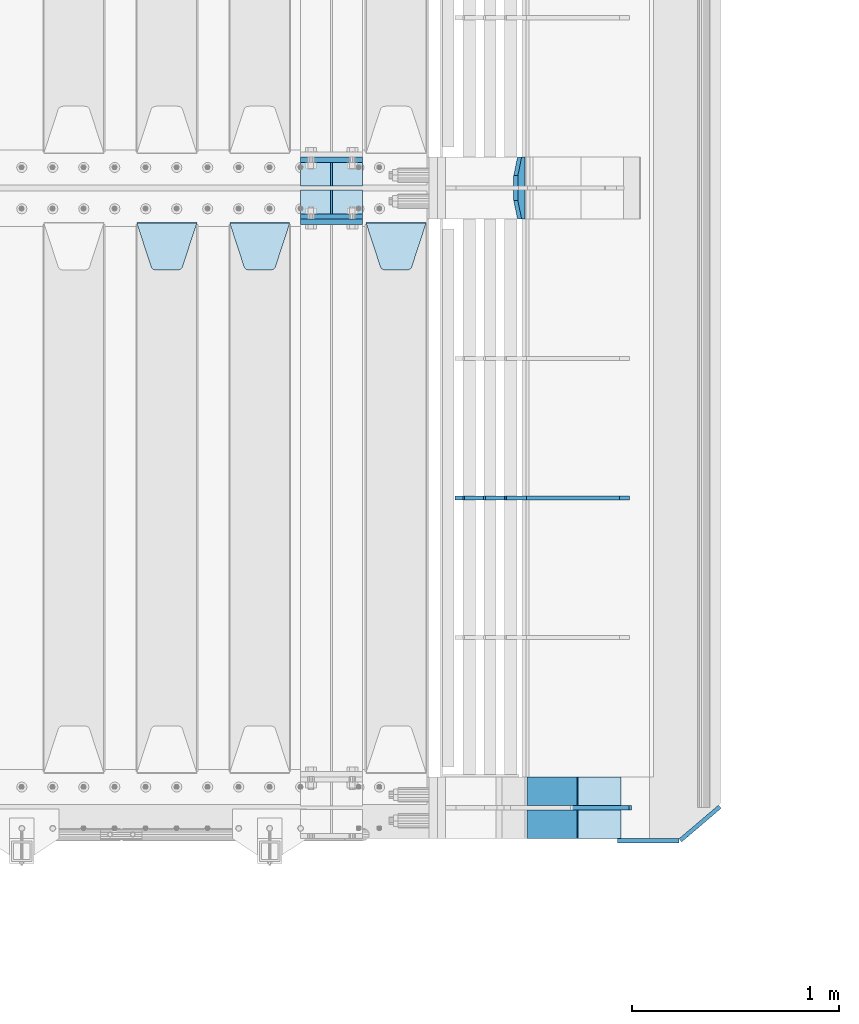
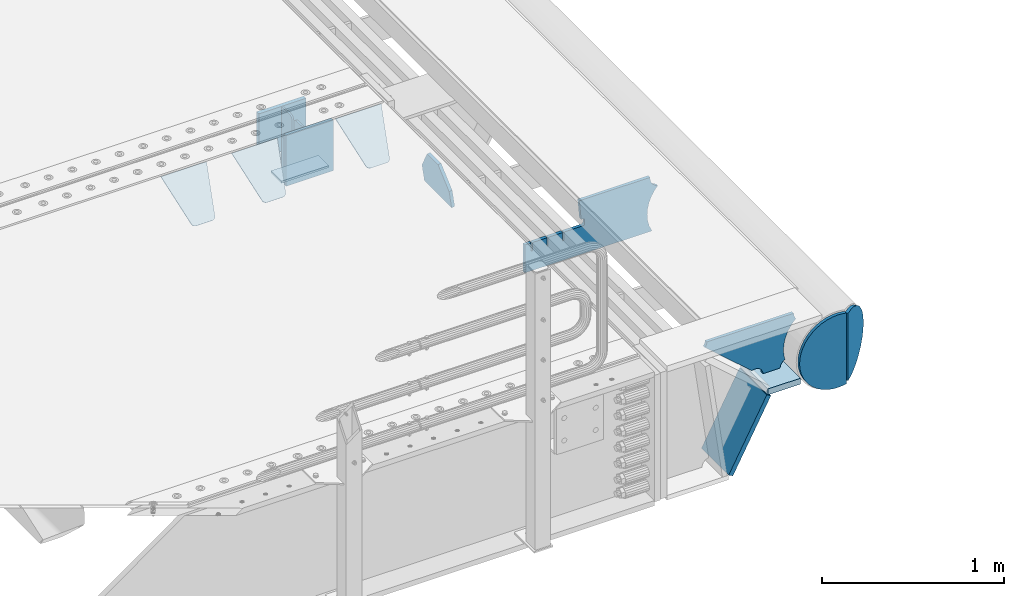
# One storey, part 243 of 270: 17 plates.
"""IFC2X3 building model written with IfcOpenShell, lengths in millimetres."""

from ifc_helpers import new_model, si_unit, frame, origin_with_axes, place, context, subcontext, project, spatial, faceted_brep, material, type_object, element, save


model = new_model("IFC2X3")

# Units and contexts
model_context = context("Model", 3, precision=1e-05, world=origin_with_axes())
body_context = subcontext(model_context, "Body", "Model", "MODEL_VIEW")
ifc_project = project(units=[si_unit("LENGTHUNIT", "METRE", prefix="MILLI"), si_unit("AREAUNIT", "SQUARE_METRE"), si_unit("VOLUMEUNIT", "CUBIC_METRE"), si_unit("MASSUNIT", "GRAM", prefix="KILO"), si_unit("TIMEUNIT", "SECOND"), si_unit("PLANEANGLEUNIT", "RADIAN"), si_unit("SOLIDANGLEUNIT", "STERADIAN"), si_unit("THERMODYNAMICTEMPERATUREUNIT", "DEGREE_CELSIUS"), si_unit("LUMINOUSINTENSITYUNIT", "LUMEN")], contexts=[model_context])

# Site, building, storey
site_placement = place(None, origin_with_axes())
site = spatial("IfcSite", under=ifc_project, at=site_placement, CompositionType="ELEMENT")
building_placement = place(site_placement, origin_with_axes())
building = spatial("IfcBuilding", under=site, at=building_placement, Name="Standard", CompositionType="ELEMENT")
storey_placement = place(building_placement, origin_with_axes())
storey = spatial("IfcBuildingStorey", under=building, at=storey_placement, Name="Undefined", CompositionType="ELEMENT", Elevation=0.0)

# Plates
ifc_material = material(Name="STEEL/S355N")
plate_type_1 = type_object("IfcPlateType", PredefinedType="NOTDEFINED")
for number, where, z_axis, x_axis in (
    (1, (19768.0, -20862.5, -339.99999999999), (0.0, 0.0, 1.0), (1.0, 0.0, 0.0)),
    (2, (19768.0, -21137.5, -339.99999999999), (0.0, 0.0, 1.0), (1.0, 0.0, 0.0)),
):
    element("IfcPlate", number, at=place(storey_placement, frame(where, z_axis=z_axis, x_axis=x_axis)), inside=storey, type_object=plate_type_1, material=ifc_material, context=body_context, shape_type="Brep", body=[
        faceted_brep([(0.0, -12.5, 0.0), (0.0, -12.5, 305.0), (0.0, 12.5, 305.0), (0.0, 12.5, 0.0), (300.0, -12.5, 305.0), (300.0, 12.5, 305.0), (300.0, -12.5, 0.0), (300.0, 12.5, 0.0)], [[[0, 1, 2, 3]], [[1, 4, 5, 2]], [[4, 6, 7, 5]], [[6, 0, 3, 7]], [[5, 7, 3, 2]], [[6, 4, 1, 0]]]),
    ])
plate_1_placement = place(storey_placement, frame((19768.0, -21162.5, -340.000000000044), z_axis=(0.0, 0.0, 1.0), x_axis=(1.0, 0.0, 0.0)))
element("IfcPlate", 3, at=plate_1_placement, inside=storey, type_object=plate_type_1, material=ifc_material, context=body_context, shape_type="Brep", body=[
    faceted_brep([(0.0, -12.5, 0.0), (9.27684595808387e-10, -12.5, 340.0), (9.27684595808387e-10, 12.5, 340.0), (0.0, 12.5, 0.0), (300.0, -12.5, 340.0), (300.0, 12.5, 340.0), (300.0, -12.5, 0.0), (300.0, 12.5, 0.0)], [[[0, 1, 2, 3]], [[1, 4, 5, 2]], [[4, 6, 7, 5]], [[6, 0, 3, 7]], [[5, 7, 3, 2]], [[6, 4, 1, 0]]]),
])
plate_type_2 = type_object("IfcPlateType", PredefinedType="NOTDEFINED")
for number, where, z_axis, x_axis in (
    (4, (19768.0, -20990.75, -342.99999999999), (0.0, 1.0, 0.0), (1.0, 0.0, 0.0)),
    (5, (19768.0, -21009.25, -342.99999999999), (0.0, -1.0, 0.0), (1.0, 0.0, 0.0)),
):
    element("IfcPlate", number, at=place(storey_placement, frame(where, z_axis=z_axis, x_axis=x_axis)), inside=storey, type_object=plate_type_2, material=ifc_material, context=body_context, shape_type="Brep", body=[
        faceted_brep([(0.0, -7.0, 0.0), (0.0, -7.0, 115.75), (0.0, 7.0, 115.75), (0.0, 7.0, 0.0), (300.0, -7.0, 115.75), (300.0, 7.0, 115.75), (300.0, -7.0, 0.0), (300.0, 7.0, 0.0)], [[[0, 1, 2, 3]], [[1, 4, 5, 2]], [[4, 6, 7, 5]], [[6, 0, 3, 7]], [[5, 7, 3, 2]], [[6, 4, 1, 0]]]),
    ])
plate_type_3 = type_object("IfcPlateType", PredefinedType="NOTDEFINED")
for number, where, z_axis, x_axis in (
    (6, (19918.0, -21009.25, -34.9999999999899), (0.0, 0.0, -1.0), (0.0, -1.0, 0.0)),
    (7, (19918.0, -20990.75, -34.9999999999899), (0.0, 0.0, -1.0), (0.0, 1.0, 0.0)),
):
    element("IfcPlate", number, at=place(storey_placement, frame(where, z_axis=z_axis, x_axis=x_axis)), inside=storey, type_object=plate_type_3, material=ifc_material, context=body_context, shape_type="Brep", body=[
        faceted_brep([(0.0, -5.0, 30.0), (0.0, -5.0, 301.0), (0.0, 5.0, 301.0), (0.0, 5.0, 30.0), (115.75, -5.0, 301.0), (115.75, 5.0, 301.0), (115.75, -5.0, 0.0), (115.75, 5.0, 0.0), (30.0, -5.0, 0.0), (30.0, 5.0, 0.0), (24.7905546699913, -5.0, 0.455767409633758), (24.7905546699913, 5.0, 0.455767409633758), (19.7393957002314, -5.0, 1.80922137642275), (19.7393957002314, 5.0, 1.80922137642275), (15.0, -5.0, 4.01923788646684), (15.0, 5.0, 4.01923788646684), (10.7163717094045, -5.0, 7.01866670643066), (10.7163717094045, 5.0, 7.01866670643066), (7.01866670642994, -5.0, 10.7163717094038), (7.01866670642994, 5.0, 10.7163717094038), (4.01923788646673, -5.0, 15.0), (4.01923788646673, 5.0, 15.0), (1.80922137642119, -5.0, 19.7393957002299), (1.80922137642119, 5.0, 19.7393957002299), (0.455767409632244, -5.0, 24.7905546699921), (0.455767409632244, 5.0, 24.7905546699921)], [[[0, 1, 2, 3]], [[1, 4, 5, 2]], [[4, 6, 7, 5]], [[6, 8, 9, 7]], [[8, 10, 11, 9]], [[10, 12, 13, 11]], [[12, 14, 15, 13]], [[14, 16, 17, 15]], [[16, 18, 19, 17]], [[18, 20, 21, 19]], [[20, 22, 23, 21]], [[22, 24, 25, 23]], [[24, 0, 3, 25]], [[5, 7, 9, 11, 13, 15, 17, 19, 21, 23, 25, 3, 2]], [[24, 22, 20, 18, 16, 14, 12, 10, 8, 6, 4, 1, 0]]]),
    ])
plate_type_4 = type_object("IfcPlateType", PredefinedType="NOTDEFINED")
plate_2_placement = place(storey_placement, frame((20085.0, -21168.232233044, -1.76776695296576), z_axis=(0.0, -0.707106781186548, -0.707106781186547), x_axis=(1.0, 0.0, 0.0)))
element("IfcPlate", 8, at=plate_2_placement, inside=storey, type_object=plate_type_4, material=ifc_material, context=body_context, shape_type="Brep", body=[
    faceted_brep([(0.0, -2.5, 0.0), (69.345504679477, -2.5, 300.171731424831), (69.345504679477, 2.5, 300.171731424831), (0.0, 2.5, 0.0), (70.9274061199576, -2.5, 304.8974424154), (70.9274061199576, 2.5, 304.8974424154), (73.3818627772307, -2.49999999999818, 309.234538108527), (73.3818627772307, 2.50000000000182, 309.234538108527), (76.6187032999551, -2.5, 313.023683126103), (76.6187032999551, 2.5, 313.023683126103), (80.5190132704993, -2.5, 316.125672595372), (80.5190132704993, 2.50000000000182, 316.125672595372), (84.9395038596849, -2.49999999999818, 318.426546230476), (84.9395038596849, 2.5, 318.426546230476), (89.7177759439219, -2.49999999999818, 319.841774983275), (89.7177759439219, 2.50000000000182, 319.841774983275), (94.678286292652, -2.5, 320.319366455078), (94.678286292652, 2.5, 320.319366455078), (195.321713707348, -2.5, 320.319366455078), (195.321713707348, 2.5, 320.319366455078), (200.282224056078, -2.49999999999818, 319.841774983275), (200.282224056078, 2.50000000000182, 319.841774983275), (205.060496140315, -2.5, 318.426546230476), (205.060496140315, 2.5, 318.426546230476), (209.480986729501, -2.5, 316.12567259537), (209.480986729501, 2.50000000000182, 316.12567259537), (213.381296700045, -2.5, 313.023683126103), (213.381296700045, 2.5, 313.023683126103), (216.618137222769, -2.49999999999818, 309.234538108525), (216.618137222769, 2.50000000000182, 309.234538108527), (219.072593880042, -2.49999999999818, 304.897442415398), (219.072593880042, 2.50000000000182, 304.897442415397), (220.654495320523, -2.5, 300.171731424831), (220.654495320523, 2.5, 300.171731424831), (290.0, -2.49999999999818, 0.0), (290.0, 2.5, 0.0)], [[[0, 1, 2, 3]], [[1, 4, 5, 2]], [[4, 6, 7, 5]], [[6, 8, 9, 7]], [[8, 10, 11, 9]], [[10, 12, 13, 11]], [[12, 14, 15, 13]], [[14, 16, 17, 15]], [[16, 18, 19, 17]], [[18, 20, 21, 19]], [[20, 22, 23, 21]], [[22, 24, 25, 23]], [[24, 26, 27, 25]], [[26, 28, 29, 27]], [[28, 30, 31, 29]], [[30, 32, 33, 31]], [[32, 34, 35, 33]], [[34, 0, 3, 35]], [[5, 7, 9, 11, 13, 15, 17, 19, 21, 23, 25, 27, 29, 31, 33, 35, 3, 2]], [[34, 32, 30, 28, 26, 24, 22, 20, 18, 16, 14, 12, 10, 8, 6, 4, 1, 0]]]),
])
plate_3_placement = place(storey_placement, frame((19425.0, -21168.232233044, -1.76776695296576), z_axis=(0.0, -0.707106781186548, -0.707106781186547), x_axis=(1.0, 0.0, 0.0)))
element("IfcPlate", 9, at=plate_3_placement, inside=storey, type_object=plate_type_4, material=ifc_material, context=body_context, shape_type="Brep", body=[
    faceted_brep([(0.0, -2.5, 0.0), (69.345504679477, -2.5, 300.171731424831), (69.345504679477, 2.5, 300.171731424831), (0.0, 2.5, 0.0), (70.9274061199576, -2.5, 304.8974424154), (70.9274061199576, 2.5, 304.8974424154), (73.3818627772307, -2.49999999999818, 309.234538108527), (73.3818627772307, 2.50000000000182, 309.234538108527), (76.6187032999551, -2.5, 313.023683126103), (76.6187032999551, 2.5, 313.023683126103), (80.5190132704993, -2.5, 316.125672595372), (80.5190132704993, 2.50000000000182, 316.125672595372), (84.9395038596849, -2.49999999999818, 318.426546230476), (84.9395038596849, 2.5, 318.426546230476), (89.7177759439219, -2.49999999999818, 319.841774983275), (89.7177759439219, 2.50000000000182, 319.841774983275), (94.678286292652, -2.5, 320.319366455078), (94.678286292652, 2.5, 320.319366455078), (195.321713707348, -2.5, 320.319366455078), (195.321713707348, 2.5, 320.319366455078), (200.282224056078, -2.49999999999818, 319.841774983275), (200.282224056078, 2.50000000000182, 319.841774983275), (205.060496140315, -2.5, 318.426546230476), (205.060496140315, 2.5, 318.426546230476), (209.480986729501, -2.5, 316.12567259537), (209.480986729501, 2.50000000000182, 316.12567259537), (213.381296700045, -2.5, 313.023683126103), (213.381296700045, 2.5, 313.023683126103), (216.618137222769, -2.49999999999818, 309.234538108525), (216.618137222769, 2.50000000000182, 309.234538108527), (219.072593880042, -2.49999999999818, 304.897442415398), (219.072593880042, 2.50000000000182, 304.897442415397), (220.654495320523, -2.5, 300.171731424831), (220.654495320523, 2.5, 300.171731424831), (290.0, -2.49999999999818, 0.0), (290.0, 2.5, 0.0)], [[[0, 1, 2, 3]], [[1, 4, 5, 2]], [[4, 6, 7, 5]], [[6, 8, 9, 7]], [[8, 10, 11, 9]], [[10, 12, 13, 11]], [[12, 14, 15, 13]], [[14, 16, 17, 15]], [[16, 18, 19, 17]], [[18, 20, 21, 19]], [[20, 22, 23, 21]], [[22, 24, 25, 23]], [[24, 26, 27, 25]], [[26, 28, 29, 27]], [[28, 30, 31, 29]], [[30, 32, 33, 31]], [[32, 34, 35, 33]], [[34, 0, 3, 35]], [[5, 7, 9, 11, 13, 15, 17, 19, 21, 23, 25, 27, 29, 31, 33, 35, 3, 2]], [[34, 32, 30, 28, 26, 24, 22, 20, 18, 16, 14, 12, 10, 8, 6, 4, 1, 0]]]),
])
plate_4_placement = place(storey_placement, frame((18975.0, -21168.232233044, -1.76776695296576), z_axis=(0.0, -0.707106781186548, -0.707106781186547), x_axis=(1.0, 0.0, 0.0)))
element("IfcPlate", 10, at=plate_4_placement, inside=storey, type_object=plate_type_4, material=ifc_material, context=body_context, shape_type="Brep", body=[
    faceted_brep([(0.0, -2.5, 0.0), (69.345504679477, -2.5, 300.171731424831), (69.345504679477, 2.5, 300.171731424831), (0.0, 2.5, 0.0), (70.9274061199576, -2.5, 304.8974424154), (70.9274061199576, 2.5, 304.8974424154), (73.3818627772307, -2.49999999999818, 309.234538108527), (73.3818627772307, 2.50000000000182, 309.234538108527), (76.6187032999551, -2.5, 313.023683126103), (76.6187032999551, 2.5, 313.023683126103), (80.5190132704993, -2.5, 316.125672595372), (80.5190132704993, 2.50000000000182, 316.125672595372), (84.9395038596849, -2.49999999999818, 318.426546230476), (84.9395038596849, 2.5, 318.426546230476), (89.7177759439219, -2.49999999999818, 319.841774983275), (89.7177759439219, 2.50000000000182, 319.841774983275), (94.678286292652, -2.5, 320.319366455078), (94.678286292652, 2.5, 320.319366455078), (195.321713707348, -2.5, 320.319366455078), (195.321713707348, 2.5, 320.319366455078), (200.282224056078, -2.49999999999818, 319.841774983275), (200.282224056078, 2.50000000000182, 319.841774983275), (205.060496140315, -2.5, 318.426546230476), (205.060496140315, 2.5, 318.426546230476), (209.480986729501, -2.5, 316.12567259537), (209.480986729501, 2.50000000000182, 316.12567259537), (213.381296700045, -2.5, 313.023683126103), (213.381296700045, 2.5, 313.023683126103), (216.618137222769, -2.49999999999818, 309.234538108525), (216.618137222769, 2.50000000000182, 309.234538108527), (219.072593880042, -2.49999999999818, 304.897442415398), (219.072593880042, 2.50000000000182, 304.897442415397), (220.654495320523, -2.5, 300.171731424831), (220.654495320523, 2.5, 300.171731424831), (290.0, -2.49999999999818, 0.0), (290.0, 2.5, 0.0)], [[[0, 1, 2, 3]], [[1, 4, 5, 2]], [[4, 6, 7, 5]], [[6, 8, 9, 7]], [[8, 10, 11, 9]], [[10, 12, 13, 11]], [[12, 14, 15, 13]], [[14, 16, 17, 15]], [[16, 18, 19, 17]], [[18, 20, 21, 19]], [[20, 22, 23, 21]], [[22, 24, 25, 23]], [[24, 26, 27, 25]], [[26, 28, 29, 27]], [[28, 30, 31, 29]], [[30, 32, 33, 31]], [[32, 34, 35, 33]], [[34, 0, 3, 35]], [[5, 7, 9, 11, 13, 15, 17, 19, 21, 23, 25, 27, 29, 31, 33, 35, 3, 2]], [[34, 32, 30, 28, 26, 24, 22, 20, 18, 16, 14, 12, 10, 8, 6, 4, 1, 0]]]),
])
plate_type_5 = type_object("IfcPlateType", PredefinedType="NOTDEFINED")
plate_5_placement = place(storey_placement, frame((20844.0775331947, -20849.9999999983, -871.412303810021), z_axis=(0.0, -1.0, 0.0), x_axis=(-0.137902988002447, 0.0, 0.990445741017648)))
element("IfcPlate", 11, at=plate_5_placement, inside=storey, type_object=plate_type_5, material=ifc_material, context=body_context, shape_type="Brep", body=[
    faceted_brep([(0.0, -10.0, 0.0), (-1.98724592337385e-10, -10.0000000000036, 300.0), (-1.98724592337385e-10, 10.0, 300.0), (0.0, 10.0, 0.0), (115.0, -10.0000000000036, 300.0), (115.0, 9.99999999999272, 300.0), (250.0, -10.0, 210.0), (250.0, 9.99999999999636, 210.0), (250.0, -10.0, 90.0), (250.0, 9.99999999999636, 90.0), (115.0, -10.0000000000036, -1.09139364212751e-10), (115.0, 9.99999999999272, -1.09139364212751e-10)], [[[0, 1, 2, 3]], [[1, 4, 5, 2]], [[4, 6, 7, 5]], [[6, 8, 9, 7]], [[8, 10, 11, 9]], [[10, 0, 3, 11]], [[5, 7, 9, 11, 3, 2]], [[10, 8, 6, 4, 1, 0]]]),
])
plate_type_6 = type_object("IfcPlateType", PredefinedType="NOTDEFINED")
plate_6_placement = place(storey_placement, frame((21111.9988298898, -24150.0000000008, -387.999999998825), z_axis=(1.0, 0.0, 0.0), x_axis=(0.0, 1.0, 0.0)))
element("IfcPlate", 12, at=plate_6_placement, inside=storey, type_object=plate_type_6, material=ifc_material, context=body_context, shape_type="Brep", body=[
    faceted_brep([(0.0, -20.0, 0.0), (3.31056071445346e-10, -20.0, 208.0), (3.31056071445346e-10, 20.0, 208.0), (0.0, 20.0, 0.0), (300.0, -20.0, 208.0), (300.0, 20.0, 208.0), (300.0, -20.0, -1.81898940354586e-12), (300.0, 20.0, -1.81898940354586e-12)], [[[0, 1, 2, 3]], [[1, 4, 5, 2]], [[4, 6, 7, 5]], [[6, 0, 3, 7]], [[5, 7, 3, 2]], [[6, 4, 1, 0]]]),
])
plate_type_7 = type_object("IfcPlateType", PredefinedType="NOTDEFINED")
plate_7_placement = place(storey_placement, frame((21426.9988298898, -24000.0000000006, -29.9999999988253), z_axis=(-0.000446694000102124, 0.0, -0.99999990023223), x_axis=(-0.99999990023223, 0.0, 0.000446694000103734)))
element("IfcPlate", 13, at=plate_7_placement, inside=storey, type_object=plate_type_7, material=ifc_material, context=body_context, shape_type="Brep", body=[
    faceted_brep([(125.007775472979, 10.0, 291.842314882029), (131.755016800053, 10.0, 263.793234614468), (131.755016800053, -10.0, 263.793234614468), (125.007775472979, -10.0, 291.842314882029), (134.899927074483, 10.0, 224.060281342732), (134.899927074483, -10.0, 224.060281342732), (131.79051499522, 10.0, 184.324534302446), (131.79051499522, -10.0, 184.324534302446), (122.503344607208, 10.0, 145.564419461128), (122.503344607208, -10.0, 145.564419461128), (107.267096867745, 10.0, 108.734339483616), (107.267096867745, -10.0, 108.734339483616), (86.4569387623887, 10.0, 74.741173170983), (86.4569387623887, -10.0, 74.741173170983), (60.5852854486511, 10.0, 44.4219450946983), (60.5852854486511, -10.0, 44.4219450946983), (56.2519855253086, 10.0, 40.7176084148888), (56.2519855253086, -10.0, 40.7176084148888), (136.409234539125, -10.0, 297.721677540594), (147.386991180581, -10.0, 308.778803581017), (147.386991180581, 10.0, 308.778803581017), (136.409234539125, 10.0, 297.721677540594), (154.428166132755, -10.0, 322.678193223937), (154.428166132755, 10.0, 322.678193223937), (156.849001662977, -10.0, 338.070097995228), (156.849001662977, 10.0, 338.070097995228), (264.849004013293, -10.0, 338.118348049693), (264.849004013293, 10.0, 338.118348049693), (267.62876711955, -10.0, 321.701412969031), (267.62876711955, 10.0, 321.701412969031), (275.645118712178, -10.0, 307.107546191754), (275.645118712178, 10.0, 307.107546191754), (288.009068357209, -10.0, 295.955165748785), (288.009068357209, 10.0, 295.955165748785), (303.34948944753, -10.0, 289.481038692482), (303.34948944753, 10.0, 289.481038692482), (319.965173216926, -10.0, 288.403127172445), (319.965173216926, 10.0, 288.403127172445), (336.013487920231, -10.0, 292.840968489265), (336.013487920231, 10.0, 292.840968489265), (335.869079589844, -10.0, 293.150054931641), (335.869079589844, 10.0, 293.150054931641), (633.937057436444, -10.0, 32.8861672876965), (633.937057436444, 10.0, 32.8861672876965), (628.672097726401, -10.0, 25.6357574923157), (628.672097726401, 10.0, 25.6357574923157), (624.785781531271, -10.0, 17.5620477266101), (624.785781531271, 10.0, 17.5620477266101), (622.402919050601, -10.0, 8.92432757904926), (622.402919050601, 10.0, 8.92432757904926), (621.600036621097, -10.0, -8.74678107720683e-10), (621.600036621097, 10.0, -8.74678107720683e-10), (70.0, -10.0, -9.85025394584227e-11), (70.0, 10.0, -9.85025394584227e-11), (67.7728137216618, -10.0, 17.5170123094482), (67.7728137216618, 10.0, 17.5170123094482), (61.2329794213983, -10.0, 33.9193489203215), (61.2329794213983, 10.0, 33.9193489203215)], [[[0, 1, 2, 3]], [[4, 5, 2, 1]], [[6, 7, 5, 4]], [[8, 9, 7, 6]], [[10, 11, 9, 8]], [[12, 13, 11, 10]], [[14, 15, 13, 12]], [[16, 17, 15, 14]], [[18, 19, 20, 21]], [[19, 22, 23, 20]], [[22, 24, 25, 23]], [[24, 26, 27, 25]], [[26, 28, 29, 27]], [[28, 30, 31, 29]], [[30, 32, 33, 31]], [[32, 34, 35, 33]], [[34, 36, 37, 35]], [[36, 38, 39, 37]], [[38, 40, 41, 39]], [[40, 42, 43, 41]], [[42, 44, 45, 43]], [[44, 46, 47, 45]], [[46, 48, 49, 47]], [[48, 50, 51, 49]], [[50, 52, 53, 51]], [[52, 54, 55, 53]], [[54, 56, 57, 55]], [[12, 10, 8, 6, 4, 1, 0, 21, 20, 23, 25, 27, 29, 31, 33, 35, 37, 39, 41, 43, 45, 47, 49, 51, 53, 55, 57, 16, 14]], [[18, 21, 0, 3]], [[56, 54, 52, 50, 48, 46, 44, 42, 40, 38, 36, 34, 32, 30, 28, 26, 24, 22, 19, 18, 3, 2, 5, 7, 9, 11, 13, 15, 17]], [[57, 56, 17, 16]]]),
])
plate_type_8 = type_object("IfcPlateType", PredefinedType="NOTDEFINED")
plate_8_placement = place(storey_placement, frame((20876.2468009574, -23849.999999999, -867.038754737558), z_axis=(0.469471552246176, 0.0, 0.882947598462992), x_axis=(0.0, -1.0, 0.0)))
element("IfcPlate", 14, at=plate_8_placement, inside=storey, type_object=plate_type_8, material=ifc_material, context=body_context, shape_type="Brep", body=[
    faceted_brep([(0.0, -15.0, 0.0), (0.0, -15.0, 515.000000000002), (0.0, 15.0000000000036, 515.000000000004), (0.0, 15.0, 0.0), (300.0, -15.0, 515.000000000002), (300.0, 15.0000000000036, 515.000000000004), (300.0, -15.0, 0.0), (300.0, 15.0, 0.0)], [[[0, 1, 2, 3]], [[1, 4, 5, 2]], [[4, 6, 7, 5]], [[6, 0, 3, 7]], [[5, 7, 3, 2]], [[6, 4, 1, 0]]]),
])
plate_type_9 = type_object("IfcPlateType", PredefinedType="NOTDEFINED")
plate_9_placement = place(storey_placement, frame((21355.9182339676, -22500.0007171631, -374.002067436517), z_axis=(0.0, 0.0, 1.0), x_axis=(-1.0, 0.0, 0.0)))
element("IfcPlate", 15, at=plate_9_placement, inside=storey, type_object=plate_type_9, material=ifc_material, context=body_context, shape_type="Brep", body=[
    faceted_brep([(801.919404066546, -10.0, 188.0), (801.919404066546, 10.0, 188.0), (801.919404066546, 10.0, 132.002067436952), (801.919404066546, -10.0, 132.002067436952), (793.919404066546, 10.0, 132.002067436952), (793.919404066546, -10.0, 132.002067436952), (793.919404066546, 10.0, 180.002067436952), (793.919404066546, -10.0, 180.002067436952), (793.527856196906, 10.0, 182.474203391951), (793.527856196906, -10.0, 182.474203391951), (792.391540021545, 10.0, 184.704349455291), (792.391540021545, -10.0, 184.704349455291), (790.621686084887, 10.0, 186.474203391951), (790.621686084887, -10.0, 186.474203391951), (788.391540021545, 10.0, 187.610519567313), (788.391540021545, -10.0, 187.610519567313), (785.919404066546, -10.0, 188.002067436952), (785.919404066546, 10.0, 188.0), (841.0, -10.0, 188.0), (841.0, -10.0, 0.0), (841.0, 10.0, 0.0), (841.0, 10.0, 188.0), (33.3619566735979, -10.0, 0.0), (33.3619566735979, 10.0, 0.0), (36.2350612208174, -10.0, 4.68848050267013), (36.2350612208174, 10.0, 4.68848050267013), (51.4877592159428, -10.0, 41.5117508652784), (51.4877592159428, 10.0, 41.5117508652784), (60.792242588137, -10.0, 80.2677133162964), (60.792242588137, 10.0, 80.2677133162964), (63.9194040769726, -10.0, 120.002067436515), (63.9194040769726, 10.0, 120.002067436515), (60.792242588137, -10.0, 159.736421556734), (60.792242588137, 10.0, 159.736421556734), (51.4877592159428, -10.0, 198.492384007752), (51.4877592159428, 10.0, 198.492384007752), (36.2350612208174, -10.0, 235.31565437036), (36.2350612208174, 10.0, 235.31565437036), (15.4097206482074, -10.0, 269.299521518803), (15.4097206482074, 10.0, 269.299521518803), (-3.35474438098754, -10.0, 291.269887256574), (-3.35474438098754, 10.0, 291.269887256574), (-2.36881039375294, -10.0, 291.426043859339), (-2.36881039375294, 10.0, 291.426043859339), (17.1449676604716, -10.0, 301.368810393754), (17.1449676604716, 10.0, 301.368810393754), (32.6311896062471, -10.0, 316.855032339527), (32.6311896062471, 10.0, 316.855032339527), (42.573956140659, -10.0, 336.368810393754), (42.573956140659, 10.0, 336.368810393754), (46.0, -10.0, 358.0), (46.0, 10.0, 358.0), (45.0495205499174, -10.0, 364.001091067617), (45.0495205499174, 10.0, 364.001091067617), (495.040008544922, -10.0, 364.010009765625), (495.040008544922, 10.0, 364.010009765625), (483.600036621094, -10.0, 233.759994506836), (483.600036621094, 10.0, 233.759994506836), (472.0, -10.0, 233.759994506836), (472.0, 10.0, 233.759994506836), (468.909830056251, -10.0, 233.270559669787), (468.909830056251, 10.0, 233.270559669787), (466.122147477075, -10.0, 231.850164450585), (466.122147477075, 10.0, 231.850164450585), (463.909830056251, -10.0, 229.637847029761), (463.909830056251, 10.0, 229.637847029761), (462.489434837047, -10.0, 226.850164450585), (462.489434837047, 10.0, 226.850164450585), (462.0, -10.0, 223.759994506836), (462.0, 10.0, 223.759994506836), (462.0, -10.0, 198.0), (462.0, 10.0, 198.0), (462.489434837047, -10.0, 194.909830056251), (462.489434837047, 10.0, 194.909830056251), (463.909830056251, -10.0, 192.122147477075), (463.909830056251, 10.0, 192.122147477075), (466.122147477075, -10.0, 189.909830056251), (466.122147477075, 10.0, 189.909830056251), (468.909830056251, -10.0, 188.489434837048), (468.909830056251, 10.0, 188.489434837048), (472.0, -10.0, 188.0), (472.0, 10.0, 188.0), (585.919404066546, -10.0, 188.002067436952), (585.919404066546, 10.0, 188.0), (588.391540021545, -10.0, 187.610519567313), (588.391540021545, 10.0, 187.610519567313), (590.621686084887, -10.0, 186.474203391951), (590.621686084887, 10.0, 186.474203391951), (592.391540021545, -10.0, 184.704349455291), (592.391540021545, 10.0, 184.704349455291), (593.527856196906, -10.0, 182.474203391951), (593.527856196906, 10.0, 182.474203391951), (593.919404066546, -10.0, 180.002067436952), (593.919404066546, 10.0, 180.002067436952), (593.919404066546, -10.0000000000036, 132.002067436952), (593.919404066546, 10.0, 132.002067436952), (601.919404066546, -10.0000000000036, 132.002067436952), (601.919404066546, 10.0, 132.002067436952), (601.919404066546, -10.0, 188.0), (601.919404066546, 10.0, 188.0), (685.919404066546, -10.0, 188.002067436952), (685.919404066546, 10.0, 188.0), (688.391540021545, -10.0, 187.610519567313), (688.391540021545, 10.0, 187.610519567313), (690.621686084887, -10.0, 186.474203391951), (690.621686084887, 10.0, 186.474203391951), (692.391540021545, -10.0, 184.704349455291), (692.391540021545, 10.0, 184.704349455291), (693.527856196906, -10.0, 182.474203391951), (693.527856196906, 10.0, 182.474203391951), (693.919404066546, -10.0, 180.002067436952), (693.919404066546, 10.0, 180.002067436952), (693.919404066546, -10.0, 132.002067436952), (693.919404066546, 10.0, 132.002067436952), (701.919404066546, -10.0, 132.002067436952), (701.919404066546, 10.0, 132.002067436952), (701.919404066546, -10.0, 188.0), (701.919404066546, 10.0, 188.0)], [[[0, 1, 2, 3]], [[3, 2, 4, 5]], [[5, 4, 6, 7]], [[7, 6, 8, 9]], [[9, 8, 10, 11]], [[11, 10, 12, 13]], [[13, 12, 14, 15]], [[16, 15, 14, 17]], [[18, 19, 20, 21]], [[20, 19, 22, 23]], [[22, 24, 25, 23]], [[26, 27, 25, 24]], [[28, 29, 27, 26]], [[30, 31, 29, 28]], [[32, 33, 31, 30]], [[34, 35, 33, 32]], [[36, 37, 35, 34]], [[38, 39, 37, 36]], [[39, 38, 40, 41]], [[40, 42, 43, 41]], [[44, 45, 43, 42]], [[46, 47, 45, 44]], [[48, 49, 47, 46]], [[50, 51, 49, 48]], [[52, 53, 51, 50]], [[54, 55, 53, 52]], [[54, 56, 57, 55]], [[56, 58, 59, 57]], [[58, 60, 61, 59]], [[60, 62, 63, 61]], [[62, 64, 65, 63]], [[64, 66, 67, 65]], [[66, 68, 69, 67]], [[68, 70, 71, 69]], [[70, 72, 73, 71]], [[72, 74, 75, 73]], [[74, 76, 77, 75]], [[76, 78, 79, 77]], [[78, 80, 81, 79]], [[81, 80, 82, 83]], [[82, 84, 85, 83]], [[86, 87, 85, 84]], [[88, 89, 87, 86]], [[90, 91, 89, 88]], [[92, 93, 91, 90]], [[94, 95, 93, 92]], [[96, 97, 95, 94]], [[98, 99, 97, 96]], [[99, 98, 100, 101]], [[100, 102, 103, 101]], [[104, 105, 103, 102]], [[106, 107, 105, 104]], [[108, 109, 107, 106]], [[110, 111, 109, 108]], [[112, 113, 111, 110]], [[114, 115, 113, 112]], [[116, 117, 115, 114]], [[117, 116, 16, 17]], [[12, 10, 8, 6, 4, 2, 1, 21, 20, 23, 25, 27, 29, 31, 33, 35, 37, 39, 41, 43, 45, 47, 49, 51, 53, 55, 57, 59, 61, 63, 65, 67, 69, 71, 73, 75, 77, 79, 81, 83, 85, 87, 89, 91, 93, 95, 97, 99, 101, 103, 105, 107, 109, 111, 113, 115, 117, 17, 14]], [[18, 21, 1, 0]], [[116, 114, 112, 110, 108, 106, 104, 102, 100, 98, 96, 94, 92, 90, 88, 86, 84, 82, 80, 78, 76, 74, 72, 70, 68, 66, 64, 62, 60, 58, 56, 54, 52, 50, 48, 46, 44, 42, 40, 38, 36, 34, 32, 30, 28, 26, 24, 22, 19, 18, 0, 3, 5, 7, 9, 11, 13, 15, 16]]]),
])
plate_type_10 = type_object("IfcPlateType", PredefinedType="NOTDEFINED")
plate_10_placement = place(storey_placement, frame((21790.0025260065, -24160.0, -498.0), z_axis=(0.0, 0.0, 1.0), x_axis=(-1.0, 0.0, 0.0)))
element("IfcPlate", 16, at=plate_10_placement, inside=storey, type_object=plate_type_10, material=ifc_material, context=body_context, shape_type="Brep", body=[
    faceted_brep([(244.0, -10.0, 0.0), (209.275179461318, -10.0, 2.48356818105242), (209.275179461318, 10.0, 2.48356818105242), (244.0, 10.0, 0.0), (278.724820538682, -10.0, 2.48356818105236), (278.724820538682, 10.0, 2.48356818105236), (312.742743869308, -10.0, 9.88371443806261), (312.742743869308, 10.0, 9.88371443806261), (345.361263172461, -10.0, 22.0497931334975), (345.361263172461, 10.0, 22.0497931334975), (375.916359459166, -10.0, 38.7341379891918), (375.916359459166, 10.0, 38.7341379891918), (403.78601908265, -10.0, 59.597103857561), (403.78601908265, 10.0, 59.597103857561), (428.402896142437, -10.0, 84.2139809173505), (428.402896142437, 10.0, 84.2139809173505), (449.265862010809, -10.0, 112.083640540834), (449.265862010809, 10.0, 112.083640540834), (465.950206866502, -10.0, 142.63873682754), (465.950206866502, 10.0, 142.63873682754), (478.116285561937, -10.0, 175.257256130691), (478.116285561937, 10.0, 175.257256130691), (485.516431818949, -10.0, 209.275179461318), (485.516431818949, 10.0, 209.275179461318), (488.0, -10.0, 244.0), (488.0, 10.0, 244.0), (485.516431818949, -10.0, 278.724820538682), (485.516431818949, 10.0, 278.724820538682), (478.116285561937, -10.0, 312.742743869309), (478.116285561937, 10.0, 312.742743869309), (465.950206866502, -10.0, 345.36126317246), (465.950206866502, 10.0, 345.36126317246), (449.265862010809, -10.0, 375.916359459166), (449.265862010809, 10.0, 375.916359459166), (428.402896142437, -10.0, 403.78601908265), (428.402896142437, 10.0, 403.78601908265), (403.78601908265, -10.0, 428.402896142439), (403.78601908265, 10.0, 428.402896142439), (375.916359459166, -10.0, 449.265862010808), (375.916359459166, 10.0, 449.265862010808), (345.361263172461, -10.0, 465.950206866503), (345.361263172461, 10.0, 465.950206866503), (312.742743869308, -10.0, 478.116285561937), (312.742743869308, 10.0, 478.116285561937), (278.724820538682, -10.0, 485.516431818948), (278.724820538682, 10.0, 485.516431818948), (244.0, -10.0, 488.0), (244.0, 10.0, 488.0), (209.275179461318, -10.0, 485.516431818948), (209.275179461318, 10.0, 485.516431818948), (190.054561198212, -10.0, 481.33524224677), (190.05769402791, -10.0, 6.66407624784438), (190.062244034561, 10.0, 6.6630864544826), (190.0591111918, 10.0, 481.33623203729)], [[[0, 1, 2, 3]], [[4, 0, 3, 5]], [[6, 4, 5, 7]], [[8, 6, 7, 9]], [[10, 8, 9, 11]], [[12, 10, 11, 13]], [[14, 12, 13, 15]], [[16, 14, 15, 17]], [[18, 16, 17, 19]], [[20, 18, 19, 21]], [[22, 20, 21, 23]], [[24, 22, 23, 25]], [[26, 24, 25, 27]], [[28, 26, 27, 29]], [[30, 28, 29, 31]], [[32, 30, 31, 33]], [[34, 32, 33, 35]], [[36, 34, 35, 37]], [[38, 36, 37, 39]], [[40, 38, 39, 41]], [[42, 40, 41, 43]], [[44, 42, 43, 45]], [[46, 44, 45, 47]], [[48, 46, 47, 49]], [[1, 0, 4, 6, 8, 10, 12, 14, 16, 18, 20, 22, 24, 26, 28, 30, 32, 34, 36, 38, 40, 42, 44, 46, 48, 50, 51]], [[2, 1, 51, 52]], [[49, 47, 45, 43, 41, 39, 37, 35, 33, 31, 29, 27, 25, 23, 21, 19, 17, 15, 13, 11, 9, 7, 5, 3, 2, 52, 53]], [[48, 49, 53, 50]], [[52, 51, 50, 53]]]),
])
plate_type_11 = type_object("IfcPlateType", PredefinedType="NOTDEFINED")
plate_11_placement = place(storey_placement, frame((21643.671855575, -24125.9492520076, -30.6102092804236), z_axis=(-0.0672019629768904, -0.0573522459802765, -0.996089662657469), x_axis=(-0.758955820878059, -0.645120692896345, 0.0883479119858051)))
element("IfcPlate", 17, at=plate_11_placement, inside=storey, type_object=plate_type_11, material=ifc_material, context=body_context, shape_type="Brep", body=[
    faceted_brep([(0.0, -10.0, 0.0), (-48.0487670880718, -10.0, 8.67017459869364), (-48.0487670880698, 10.0000000000073, 8.67017459869378), (0.0, 10.0, 0.0), (-93.1333465523569, -9.99999999999636, 25.6771621704104), (-93.1333465523585, 10.0, 25.6771621704103), (-133.522018422307, -10.0, 50.3669776916503), (-133.522018422305, 10.0, 50.3669776916504), (-167.658004743994, -10.0, 81.7919921875002), (-167.658004743995, 10.0000000000036, 81.7919921875004), (-194.131179785259, -9.99999999999272, 118.752670288086), (-194.131179785262, 10.0, 118.752670288086), (-212.241073575684, -9.99999999999636, 159.800354003906), (-212.241073575682, 10.0000000000036, 159.800354003906), (-220.965927082382, -10.0, 203.387512207031), (-220.965927082383, 10.0000000000036, 203.387512207031), (-220.07881159477, -10.0, 247.828140258789), (-220.078811594771, 10.0000000000036, 247.828140258789), (-209.490798890533, -10.0, 291.426422119141), (-209.490798890531, 10.0000000000036, 291.426422119141), (-189.979858330369, -9.99999999999636, 332.473327636719), (-189.97985833037, 10.0, 332.473327636719), (-161.934860153859, -9.99999999999636, 369.423980712891), (-161.934860153861, 10.0, 369.423980712891), (-126.533912576627, -9.99999999999636, 400.848876953125), (-126.533912576623, 10.0, 400.848876953125), (-85.1552428328012, -10.0, 425.539093017578), (-85.1552428327991, 10.0000000000036, 425.539093017578), (-39.3886450815156, -9.99999999999636, 442.546478271484), (-39.3886450815172, 10.0000000000036, 442.546478271484), (8.99617299734768, -9.99999999999636, 451.215240478516), (8.99617299734598, 10.0000000000036, 451.215240478515), (49.1690940856973, -9.99999999999636, 2.20552465179935e-11), (49.1690940856957, 10.0, 2.17426077142591e-11)], [[[0, 1, 2, 3]], [[1, 4, 5, 2]], [[4, 6, 7, 5]], [[6, 8, 9, 7]], [[8, 10, 11, 9]], [[10, 12, 13, 11]], [[12, 14, 15, 13]], [[14, 16, 17, 15]], [[16, 18, 19, 17]], [[18, 20, 21, 19]], [[20, 22, 23, 21]], [[22, 24, 25, 23]], [[24, 26, 27, 25]], [[26, 28, 29, 27]], [[28, 30, 31, 29]], [[30, 32, 33, 31]], [[32, 0, 3, 33]], [[5, 7, 9, 11, 13, 15, 17, 19, 21, 23, 25, 27, 29, 31, 33, 3, 2]], [[32, 30, 28, 26, 24, 22, 20, 18, 16, 14, 12, 10, 8, 6, 4, 1, 0]]]),
])

save(model, "model.ifc")
